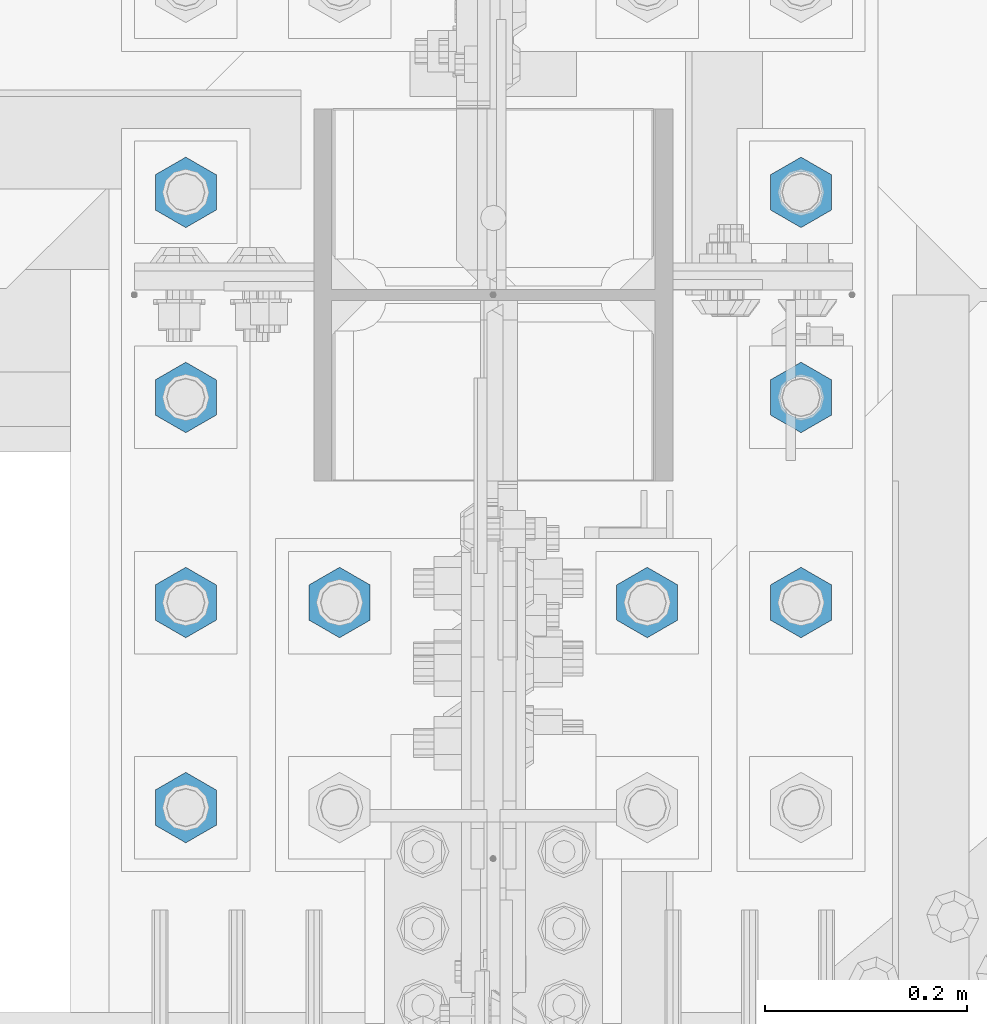
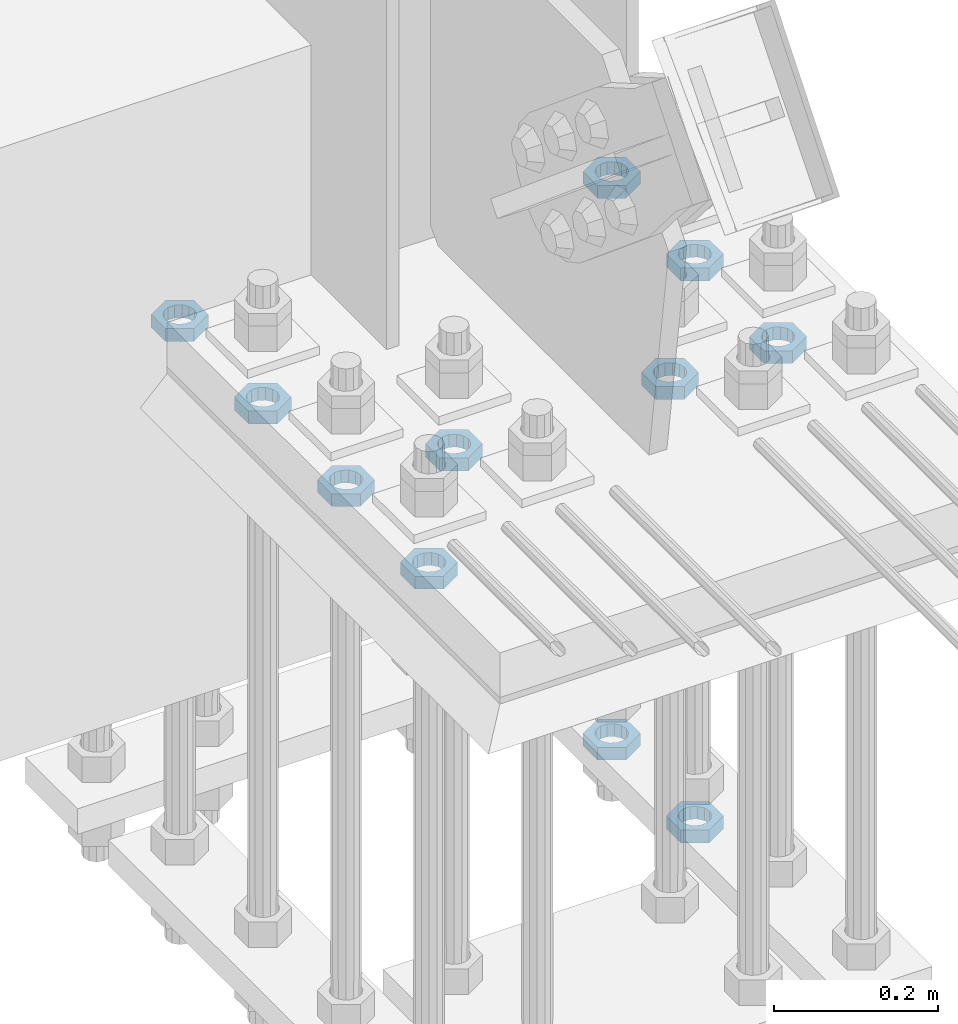
# One storey, part 2839 of 3843: 11 beams, 1 element without a shape of its own.
"""IFC2X3 building model written with IfcOpenShell, lengths in millimetres."""

from ifc_helpers import new_model, si_unit, frame, origin_with_axes, place, context, subcontext, project, spatial, faceted_brep, material, type_object, element, aggregate, save


model = new_model("IFC2X3")

# Units and contexts
model_context = context("Model", 3, precision=1e-05, world=origin_with_axes())
body_context = subcontext(model_context, "Body", "Model", "MODEL_VIEW")
ifc_project = project(units=[si_unit("LENGTHUNIT", "METRE", prefix="MILLI"), si_unit("AREAUNIT", "SQUARE_METRE"), si_unit("VOLUMEUNIT", "CUBIC_METRE"), si_unit("MASSUNIT", "GRAM", prefix="KILO"), si_unit("TIMEUNIT", "SECOND"), si_unit("PLANEANGLEUNIT", "RADIAN"), si_unit("SOLIDANGLEUNIT", "STERADIAN"), si_unit("THERMODYNAMICTEMPERATUREUNIT", "DEGREE_CELSIUS"), si_unit("LUMINOUSINTENSITYUNIT", "LUMEN")], contexts=[model_context])

# Site, building, storey
site_placement = place(None, origin_with_axes())
site = spatial("IfcSite", under=ifc_project, at=site_placement, CompositionType="ELEMENT")
building_placement = place(site_placement, origin_with_axes())
building = spatial("IfcBuilding", under=site, at=building_placement, Name="Undefined", CompositionType="ELEMENT")
storey_placement = place(building_placement, origin_with_axes())
storey = spatial("IfcBuildingStorey", under=building, at=storey_placement, Name="Undefined", CompositionType="ELEMENT", Elevation=0.0)

# Assembly, beams
assembly_placement = place(storey_placement, origin_with_axes())
assembly = element("IfcElementAssembly", 1, at=assembly_placement, inside=storey, Name="TEMPLATE", AssemblyPlace="NOTDEFINED", PredefinedType="RIGID_FRAME")
ifc_material = material(Name="STEEL/A572-50")
beam_type = type_object("IfcBeamType", Name="1-1/2_HALF_NUT", PredefinedType="NOTDEFINED")
beam_1_placement = place(assembly_placement, frame((76708.0, 25107.9, 30060.9), z_axis=(-1.0, 0.0, 0.0), x_axis=(0.0, 0.0, -1.0)))
beam_1 = element("IfcBeam", 2, at=beam_1_placement, type_object=beam_type, material=ifc_material, Name="NUT", ObjectType="1-1/2_HALF_NUT", context=body_context, shape_type="Brep", body=[
    faceted_brep([(0.0, -34.9199981689453, 0.0), (0.0, -17.4599990844727, -30.25), (19.0500000000029, -17.4599990844727, -30.25), (19.0500000000029, -34.9199981689453, 0.0), (0.0, 17.4599990844727, -30.25), (19.0500000000029, 17.4599990844727, -30.25), (0.0, 34.9199981689453, 0.0), (19.0500000000029, 34.9199981689453, 0.0), (0.0, 17.4599990844727, 30.25), (19.0500000000029, 17.4599990844727, 30.25), (0.0, -17.4599990844727, 30.25), (19.0500000000029, -17.4599990844727, 30.25), (0.0, 0.0, 20.6399993896484), (0.0, 8.9553601105581, 18.5959968835959), (19.0500000000029, 8.95536011056538, 18.5959968835959), (19.0500000000029, 0.0, 20.6399993896484), (0.0, 16.1370013209525, 12.8688291298167), (19.0500000000029, 16.1370013209489, 12.8688291298167), (0.0, 20.1225115123816, 4.59283194104501), (19.0500000000029, 20.1225115123852, 4.59283194104501), (0.0, 20.1225115123816, -4.59283194104501), (19.0500000000029, 20.1225115123852, -4.59283194104501), (0.0, 16.1370013209525, -12.8688291298167), (19.0500000000029, 16.1370013209489, -12.8688291298167), (0.0, 8.9553601105581, -18.5959968835959), (19.0500000000029, 8.95536011056538, -18.5959968835959), (0.0, 0.0, -20.6399993896484), (19.0500000000029, 0.0, -20.6399993896484), (0.0, -8.9553601105581, -18.5959968835959), (19.0500000000029, -8.95536011056538, -18.5959968835959), (0.0, -16.1370013209525, -12.8688291298167), (19.0500000000029, -16.1370013209489, -12.8688291298167), (0.0, -20.1225115123816, -4.59283194104501), (19.0500000000029, -20.1225115123852, -4.59283194104501), (0.0, -20.1225115123816, 4.59283194104501), (19.0500000000029, -20.1225115123852, 4.59283194104501), (0.0, -16.1370013209525, 12.8688291298167), (19.0500000000029, -16.1370013209489, 12.8688291298167), (0.0, -8.9553601105581, 18.5959968835959), (19.0500000000029, -8.95536011056538, 18.5959968835959)], [[[0, 1, 2, 3]], [[1, 4, 5, 2]], [[4, 6, 7, 5]], [[6, 8, 9, 7]], [[8, 10, 11, 9]], [[10, 0, 3, 11]], [[12, 13, 14, 15]], [[13, 16, 17, 14]], [[16, 18, 19, 17]], [[18, 20, 21, 19]], [[20, 22, 23, 21]], [[22, 24, 25, 23]], [[24, 26, 27, 25]], [[26, 28, 29, 27]], [[28, 30, 31, 29]], [[30, 32, 33, 31]], [[32, 34, 35, 33]], [[34, 36, 37, 35]], [[36, 38, 39, 37]], [[38, 12, 15, 39]], [[5, 7, 9, 11, 3, 2], [17, 19, 21, 23, 25, 27, 29, 31, 33, 35, 37, 39, 15, 14]], [[10, 8, 6, 4, 1, 0], [38, 36, 34, 32, 30, 28, 26, 24, 22, 20, 18, 16, 13, 12]]]),
])
beam_2_placement = place(assembly_placement, frame((77317.6, 25514.3, 30060.9), z_axis=(-1.0, 0.0, 0.0), x_axis=(0.0, 0.0, -1.0)))
beam_2 = element("IfcBeam", 3, at=beam_2_placement, type_object=beam_type, material=ifc_material, Name="NUT", ObjectType="1-1/2_HALF_NUT", context=body_context, shape_type="Brep", body=[
    faceted_brep([(0.0, -34.9199981689453, 0.0), (0.0, -17.4599990844727, -30.25), (19.0500000000029, -17.4599990844727, -30.25), (19.0500000000029, -34.9199981689453, 0.0), (0.0, 17.4599990844727, -30.25), (19.0500000000029, 17.4599990844727, -30.25), (0.0, 34.9199981689453, 0.0), (19.0500000000029, 34.9199981689453, 0.0), (0.0, 17.4599990844727, 30.25), (19.0500000000029, 17.4599990844727, 30.25), (0.0, -17.4599990844727, 30.25), (19.0500000000029, -17.4599990844727, 30.25), (0.0, 0.0, 20.6399993896484), (0.0, 8.9553601105581, 18.5959968835959), (19.0500000000029, 8.95536011056538, 18.5959968835959), (19.0500000000029, 0.0, 20.6399993896484), (0.0, 16.1370013209525, 12.8688291298167), (19.0500000000029, 16.1370013209489, 12.8688291298167), (0.0, 20.1225115123816, 4.59283194104501), (19.0500000000029, 20.1225115123852, 4.59283194104501), (0.0, 20.1225115123816, -4.59283194104501), (19.0500000000029, 20.1225115123852, -4.59283194104501), (0.0, 16.1370013209525, -12.8688291298167), (19.0500000000029, 16.1370013209489, -12.8688291298167), (0.0, 8.9553601105581, -18.5959968835959), (19.0500000000029, 8.95536011056538, -18.5959968835959), (0.0, 0.0, -20.6399993896484), (19.0500000000029, 0.0, -20.6399993896484), (0.0, -8.9553601105581, -18.5959968835959), (19.0500000000029, -8.95536011056538, -18.5959968835959), (0.0, -16.1370013209525, -12.8688291298167), (19.0500000000029, -16.1370013209489, -12.8688291298167), (0.0, -20.1225115123816, -4.59283194104501), (19.0500000000029, -20.1225115123852, -4.59283194104501), (0.0, -20.1225115123816, 4.59283194104501), (19.0500000000029, -20.1225115123852, 4.59283194104501), (0.0, -16.1370013209525, 12.8688291298167), (19.0500000000029, -16.1370013209489, 12.8688291298167), (0.0, -8.9553601105581, 18.5959968835959), (19.0500000000029, -8.95536011056538, 18.5959968835959)], [[[0, 1, 2, 3]], [[1, 4, 5, 2]], [[4, 6, 7, 5]], [[6, 8, 9, 7]], [[8, 10, 11, 9]], [[10, 0, 3, 11]], [[12, 13, 14, 15]], [[13, 16, 17, 14]], [[16, 18, 19, 17]], [[18, 20, 21, 19]], [[20, 22, 23, 21]], [[22, 24, 25, 23]], [[24, 26, 27, 25]], [[26, 28, 29, 27]], [[28, 30, 31, 29]], [[30, 32, 33, 31]], [[32, 34, 35, 33]], [[34, 36, 37, 35]], [[36, 38, 39, 37]], [[38, 12, 15, 39]], [[5, 7, 9, 11, 3, 2], [17, 19, 21, 23, 25, 27, 29, 31, 33, 35, 37, 39, 15, 14]], [[10, 8, 6, 4, 1, 0], [38, 36, 34, 32, 30, 28, 26, 24, 22, 20, 18, 16, 13, 12]]]),
])
beam_3_placement = place(assembly_placement, frame((77317.6, 25717.5, 30060.9), z_axis=(1.0, 0.0, 0.0), x_axis=(0.0, 0.0, -1.0)))
beam_3 = element("IfcBeam", 4, at=beam_3_placement, type_object=beam_type, material=ifc_material, Name="NUT", ObjectType="1-1/2_HALF_NUT", context=body_context, shape_type="Brep", body=[
    faceted_brep([(0.0, -34.9199981689453, 0.0), (0.0, -17.4599990844727, -30.25), (19.0500000000029, -17.4599990844727, -30.25), (19.0500000000029, -34.9199981689453, 0.0), (0.0, 17.4599990844727, -30.25), (19.0500000000029, 17.4599990844727, -30.25), (0.0, 34.9199981689453, 0.0), (19.0500000000029, 34.9199981689453, 0.0), (0.0, 17.4599990844727, 30.25), (19.0500000000029, 17.4599990844727, 30.25), (0.0, -17.4599990844727, 30.25), (19.0500000000029, -17.4599990844727, 30.25), (0.0, 0.0, 20.6399993896484), (0.0, 8.9553601105581, 18.5959968835959), (19.0500000000029, 8.95536011056538, 18.5959968835959), (19.0500000000029, 0.0, 20.6399993896484), (0.0, 16.1370013209525, 12.8688291298167), (19.0500000000029, 16.1370013209489, 12.8688291298167), (0.0, 20.1225115123816, 4.59283194104501), (19.0500000000029, 20.1225115123852, 4.59283194104501), (0.0, 20.1225115123816, -4.59283194104501), (19.0500000000029, 20.1225115123852, -4.59283194104501), (0.0, 16.1370013209525, -12.8688291298167), (19.0500000000029, 16.1370013209489, -12.8688291298167), (0.0, 8.9553601105581, -18.5959968835959), (19.0500000000029, 8.95536011056538, -18.5959968835959), (0.0, 0.0, -20.6399993896484), (19.0500000000029, 0.0, -20.6399993896484), (0.0, -8.9553601105581, -18.5959968835959), (19.0500000000029, -8.95536011056538, -18.5959968835959), (0.0, -16.1370013209525, -12.8688291298167), (19.0500000000029, -16.1370013209489, -12.8688291298167), (0.0, -20.1225115123816, -4.59283194104501), (19.0500000000029, -20.1225115123852, -4.59283194104501), (0.0, -20.1225115123816, 4.59283194104501), (19.0500000000029, -20.1225115123852, 4.59283194104501), (0.0, -16.1370013209525, 12.8688291298167), (19.0500000000029, -16.1370013209489, 12.8688291298167), (0.0, -8.9553601105581, 18.5959968835959), (19.0500000000029, -8.95536011056538, 18.5959968835959)], [[[0, 1, 2, 3]], [[1, 4, 5, 2]], [[4, 6, 7, 5]], [[6, 8, 9, 7]], [[8, 10, 11, 9]], [[10, 0, 3, 11]], [[12, 13, 14, 15]], [[13, 16, 17, 14]], [[16, 18, 19, 17]], [[18, 20, 21, 19]], [[20, 22, 23, 21]], [[22, 24, 25, 23]], [[24, 26, 27, 25]], [[26, 28, 29, 27]], [[28, 30, 31, 29]], [[30, 32, 33, 31]], [[32, 34, 35, 33]], [[34, 36, 37, 35]], [[36, 38, 39, 37]], [[38, 12, 15, 39]], [[5, 7, 9, 11, 3, 2], [17, 19, 21, 23, 25, 27, 29, 31, 33, 35, 37, 39, 15, 14]], [[10, 8, 6, 4, 1, 0], [38, 36, 34, 32, 30, 28, 26, 24, 22, 20, 18, 16, 13, 12]]]),
])
beam_4_placement = place(assembly_placement, frame((77317.6, 25311.1, 30060.9), z_axis=(-1.0, 0.0, 0.0), x_axis=(0.0, 0.0, -1.0)))
beam_4 = element("IfcBeam", 5, at=beam_4_placement, type_object=beam_type, material=ifc_material, Name="NUT", ObjectType="1-1/2_HALF_NUT", context=body_context, shape_type="Brep", body=[
    faceted_brep([(0.0, -34.9199981689453, 0.0), (0.0, -17.4599990844727, -30.25), (19.0500000000029, -17.4599990844727, -30.25), (19.0500000000029, -34.9199981689453, 0.0), (0.0, 17.4599990844727, -30.25), (19.0500000000029, 17.4599990844727, -30.25), (0.0, 34.9199981689453, 0.0), (19.0500000000029, 34.9199981689453, 0.0), (0.0, 17.4599990844727, 30.25), (19.0500000000029, 17.4599990844727, 30.25), (0.0, -17.4599990844727, 30.25), (19.0500000000029, -17.4599990844727, 30.25), (0.0, 0.0, 20.6399993896484), (0.0, 8.9553601105581, 18.5959968835959), (19.0500000000029, 8.95536011056538, 18.5959968835959), (19.0500000000029, 0.0, 20.6399993896484), (0.0, 16.1370013209525, 12.8688291298167), (19.0500000000029, 16.1370013209489, 12.8688291298167), (0.0, 20.1225115123816, 4.59283194104501), (19.0500000000029, 20.1225115123852, 4.59283194104501), (0.0, 20.1225115123816, -4.59283194104501), (19.0500000000029, 20.1225115123852, -4.59283194104501), (0.0, 16.1370013209525, -12.8688291298167), (19.0500000000029, 16.1370013209489, -12.8688291298167), (0.0, 8.9553601105581, -18.5959968835959), (19.0500000000029, 8.95536011056538, -18.5959968835959), (0.0, 0.0, -20.6399993896484), (19.0500000000029, 0.0, -20.6399993896484), (0.0, -8.9553601105581, -18.5959968835959), (19.0500000000029, -8.95536011056538, -18.5959968835959), (0.0, -16.1370013209525, -12.8688291298167), (19.0500000000029, -16.1370013209489, -12.8688291298167), (0.0, -20.1225115123816, -4.59283194104501), (19.0500000000029, -20.1225115123852, -4.59283194104501), (0.0, -20.1225115123816, 4.59283194104501), (19.0500000000029, -20.1225115123852, 4.59283194104501), (0.0, -16.1370013209525, 12.8688291298167), (19.0500000000029, -16.1370013209489, 12.8688291298167), (0.0, -8.9553601105581, 18.5959968835959), (19.0500000000029, -8.95536011056538, 18.5959968835959)], [[[0, 1, 2, 3]], [[1, 4, 5, 2]], [[4, 6, 7, 5]], [[6, 8, 9, 7]], [[8, 10, 11, 9]], [[10, 0, 3, 11]], [[12, 13, 14, 15]], [[13, 16, 17, 14]], [[16, 18, 19, 17]], [[18, 20, 21, 19]], [[20, 22, 23, 21]], [[22, 24, 25, 23]], [[24, 26, 27, 25]], [[26, 28, 29, 27]], [[28, 30, 31, 29]], [[30, 32, 33, 31]], [[32, 34, 35, 33]], [[34, 36, 37, 35]], [[36, 38, 39, 37]], [[38, 12, 15, 39]], [[5, 7, 9, 11, 3, 2], [17, 19, 21, 23, 25, 27, 29, 31, 33, 35, 37, 39, 15, 14]], [[10, 8, 6, 4, 1, 0], [38, 36, 34, 32, 30, 28, 26, 24, 22, 20, 18, 16, 13, 12]]]),
])
beam_5_placement = place(assembly_placement, frame((77165.2, 25311.1, 30060.9), z_axis=(-1.0, 0.0, 0.0), x_axis=(0.0, 0.0, -1.0)))
beam_5 = element("IfcBeam", 6, at=beam_5_placement, type_object=beam_type, material=ifc_material, Name="NUT", ObjectType="1-1/2_HALF_NUT", context=body_context, shape_type="Brep", body=[
    faceted_brep([(0.0, -34.9199981689453, 0.0), (0.0, -17.4599990844727, -30.25), (19.0500000000029, -17.4599990844727, -30.25), (19.0500000000029, -34.9199981689453, 0.0), (0.0, 17.4599990844727, -30.25), (19.0500000000029, 17.4599990844727, -30.25), (0.0, 34.9199981689453, 0.0), (19.0500000000029, 34.9199981689453, 0.0), (0.0, 17.4599990844727, 30.25), (19.0500000000029, 17.4599990844727, 30.25), (0.0, -17.4599990844727, 30.25), (19.0500000000029, -17.4599990844727, 30.25), (0.0, 0.0, 20.6399993896484), (0.0, 8.9553601105581, 18.5959968835959), (19.0500000000029, 8.95536011056538, 18.5959968835959), (19.0500000000029, 0.0, 20.6399993896484), (0.0, 16.1370013209525, 12.8688291298167), (19.0500000000029, 16.1370013209489, 12.8688291298167), (0.0, 20.1225115123816, 4.59283194104501), (19.0500000000029, 20.1225115123852, 4.59283194104501), (0.0, 20.1225115123816, -4.59283194104501), (19.0500000000029, 20.1225115123852, -4.59283194104501), (0.0, 16.1370013209525, -12.8688291298167), (19.0500000000029, 16.1370013209489, -12.8688291298167), (0.0, 8.9553601105581, -18.5959968835959), (19.0500000000029, 8.95536011056538, -18.5959968835959), (0.0, 0.0, -20.6399993896484), (19.0500000000029, 0.0, -20.6399993896484), (0.0, -8.9553601105581, -18.5959968835959), (19.0500000000029, -8.95536011056538, -18.5959968835959), (0.0, -16.1370013209525, -12.8688291298167), (19.0500000000029, -16.1370013209489, -12.8688291298167), (0.0, -20.1225115123816, -4.59283194104501), (19.0500000000029, -20.1225115123852, -4.59283194104501), (0.0, -20.1225115123816, 4.59283194104501), (19.0500000000029, -20.1225115123852, 4.59283194104501), (0.0, -16.1370013209525, 12.8688291298167), (19.0500000000029, -16.1370013209489, 12.8688291298167), (0.0, -8.9553601105581, 18.5959968835959), (19.0500000000029, -8.95536011056538, 18.5959968835959)], [[[0, 1, 2, 3]], [[1, 4, 5, 2]], [[4, 6, 7, 5]], [[6, 8, 9, 7]], [[8, 10, 11, 9]], [[10, 0, 3, 11]], [[12, 13, 14, 15]], [[13, 16, 17, 14]], [[16, 18, 19, 17]], [[18, 20, 21, 19]], [[20, 22, 23, 21]], [[22, 24, 25, 23]], [[24, 26, 27, 25]], [[26, 28, 29, 27]], [[28, 30, 31, 29]], [[30, 32, 33, 31]], [[32, 34, 35, 33]], [[34, 36, 37, 35]], [[36, 38, 39, 37]], [[38, 12, 15, 39]], [[5, 7, 9, 11, 3, 2], [17, 19, 21, 23, 25, 27, 29, 31, 33, 35, 37, 39, 15, 14]], [[10, 8, 6, 4, 1, 0], [38, 36, 34, 32, 30, 28, 26, 24, 22, 20, 18, 16, 13, 12]]]),
])
beam_6_placement = place(assembly_placement, frame((76860.4, 25311.1, 30060.9), z_axis=(-1.0, 0.0, 0.0), x_axis=(0.0, 0.0, -1.0)))
beam_6 = element("IfcBeam", 7, at=beam_6_placement, type_object=beam_type, material=ifc_material, Name="NUT", ObjectType="1-1/2_HALF_NUT", context=body_context, shape_type="Brep", body=[
    faceted_brep([(0.0, -34.9199981689453, 0.0), (0.0, -17.4599990844727, -30.25), (19.0500000000029, -17.4599990844727, -30.25), (19.0500000000029, -34.9199981689453, 0.0), (0.0, 17.4599990844727, -30.25), (19.0500000000029, 17.4599990844727, -30.25), (0.0, 34.9199981689453, 0.0), (19.0500000000029, 34.9199981689453, 0.0), (0.0, 17.4599990844727, 30.25), (19.0500000000029, 17.4599990844727, 30.25), (0.0, -17.4599990844727, 30.25), (19.0500000000029, -17.4599990844727, 30.25), (0.0, 0.0, 20.6399993896484), (0.0, 8.9553601105581, 18.5959968835959), (19.0500000000029, 8.95536011056538, 18.5959968835959), (19.0500000000029, 0.0, 20.6399993896484), (0.0, 16.1370013209525, 12.8688291298167), (19.0500000000029, 16.1370013209489, 12.8688291298167), (0.0, 20.1225115123816, 4.59283194104501), (19.0500000000029, 20.1225115123852, 4.59283194104501), (0.0, 20.1225115123816, -4.59283194104501), (19.0500000000029, 20.1225115123852, -4.59283194104501), (0.0, 16.1370013209525, -12.8688291298167), (19.0500000000029, 16.1370013209489, -12.8688291298167), (0.0, 8.9553601105581, -18.5959968835959), (19.0500000000029, 8.95536011056538, -18.5959968835959), (0.0, 0.0, -20.6399993896484), (19.0500000000029, 0.0, -20.6399993896484), (0.0, -8.9553601105581, -18.5959968835959), (19.0500000000029, -8.95536011056538, -18.5959968835959), (0.0, -16.1370013209525, -12.8688291298167), (19.0500000000029, -16.1370013209489, -12.8688291298167), (0.0, -20.1225115123816, -4.59283194104501), (19.0500000000029, -20.1225115123852, -4.59283194104501), (0.0, -20.1225115123816, 4.59283194104501), (19.0500000000029, -20.1225115123852, 4.59283194104501), (0.0, -16.1370013209525, 12.8688291298167), (19.0500000000029, -16.1370013209489, 12.8688291298167), (0.0, -8.9553601105581, 18.5959968835959), (19.0500000000029, -8.95536011056538, 18.5959968835959)], [[[0, 1, 2, 3]], [[1, 4, 5, 2]], [[4, 6, 7, 5]], [[6, 8, 9, 7]], [[8, 10, 11, 9]], [[10, 0, 3, 11]], [[12, 13, 14, 15]], [[13, 16, 17, 14]], [[16, 18, 19, 17]], [[18, 20, 21, 19]], [[20, 22, 23, 21]], [[22, 24, 25, 23]], [[24, 26, 27, 25]], [[26, 28, 29, 27]], [[28, 30, 31, 29]], [[30, 32, 33, 31]], [[32, 34, 35, 33]], [[34, 36, 37, 35]], [[36, 38, 39, 37]], [[38, 12, 15, 39]], [[5, 7, 9, 11, 3, 2], [17, 19, 21, 23, 25, 27, 29, 31, 33, 35, 37, 39, 15, 14]], [[10, 8, 6, 4, 1, 0], [38, 36, 34, 32, 30, 28, 26, 24, 22, 20, 18, 16, 13, 12]]]),
])
beam_7_placement = place(assembly_placement, frame((76708.0, 25717.5, 30060.9), z_axis=(1.0, 0.0, 0.0), x_axis=(0.0, 0.0, -1.0)))
beam_7 = element("IfcBeam", 8, at=beam_7_placement, type_object=beam_type, material=ifc_material, Name="NUT", ObjectType="1-1/2_HALF_NUT", context=body_context, shape_type="Brep", body=[
    faceted_brep([(0.0, -34.9199981689453, 0.0), (0.0, -17.4599990844727, -30.25), (19.0500000000029, -17.4599990844727, -30.25), (19.0500000000029, -34.9199981689453, 0.0), (0.0, 17.4599990844727, -30.25), (19.0500000000029, 17.4599990844727, -30.25), (0.0, 34.9199981689453, 0.0), (19.0500000000029, 34.9199981689453, 0.0), (0.0, 17.4599990844727, 30.25), (19.0500000000029, 17.4599990844727, 30.25), (0.0, -17.4599990844727, 30.25), (19.0500000000029, -17.4599990844727, 30.25), (0.0, 0.0, 20.6399993896484), (0.0, 8.9553601105581, 18.5959968835959), (19.0500000000029, 8.95536011056538, 18.5959968835959), (19.0500000000029, 0.0, 20.6399993896484), (0.0, 16.1370013209525, 12.8688291298167), (19.0500000000029, 16.1370013209489, 12.8688291298167), (0.0, 20.1225115123816, 4.59283194104501), (19.0500000000029, 20.1225115123852, 4.59283194104501), (0.0, 20.1225115123816, -4.59283194104501), (19.0500000000029, 20.1225115123852, -4.59283194104501), (0.0, 16.1370013209525, -12.8688291298167), (19.0500000000029, 16.1370013209489, -12.8688291298167), (0.0, 8.9553601105581, -18.5959968835959), (19.0500000000029, 8.95536011056538, -18.5959968835959), (0.0, 0.0, -20.6399993896484), (19.0500000000029, 0.0, -20.6399993896484), (0.0, -8.9553601105581, -18.5959968835959), (19.0500000000029, -8.95536011056538, -18.5959968835959), (0.0, -16.1370013209525, -12.8688291298167), (19.0500000000029, -16.1370013209489, -12.8688291298167), (0.0, -20.1225115123816, -4.59283194104501), (19.0500000000029, -20.1225115123852, -4.59283194104501), (0.0, -20.1225115123816, 4.59283194104501), (19.0500000000029, -20.1225115123852, 4.59283194104501), (0.0, -16.1370013209525, 12.8688291298167), (19.0500000000029, -16.1370013209489, 12.8688291298167), (0.0, -8.9553601105581, 18.5959968835959), (19.0500000000029, -8.95536011056538, 18.5959968835959)], [[[0, 1, 2, 3]], [[1, 4, 5, 2]], [[4, 6, 7, 5]], [[6, 8, 9, 7]], [[8, 10, 11, 9]], [[10, 0, 3, 11]], [[12, 13, 14, 15]], [[13, 16, 17, 14]], [[16, 18, 19, 17]], [[18, 20, 21, 19]], [[20, 22, 23, 21]], [[22, 24, 25, 23]], [[24, 26, 27, 25]], [[26, 28, 29, 27]], [[28, 30, 31, 29]], [[30, 32, 33, 31]], [[32, 34, 35, 33]], [[34, 36, 37, 35]], [[36, 38, 39, 37]], [[38, 12, 15, 39]], [[5, 7, 9, 11, 3, 2], [17, 19, 21, 23, 25, 27, 29, 31, 33, 35, 37, 39, 15, 14]], [[10, 8, 6, 4, 1, 0], [38, 36, 34, 32, 30, 28, 26, 24, 22, 20, 18, 16, 13, 12]]]),
])
beam_8_placement = place(assembly_placement, frame((76708.0, 25514.3, 30060.9), z_axis=(-1.0, 0.0, 0.0), x_axis=(0.0, 0.0, -1.0)))
beam_8 = element("IfcBeam", 9, at=beam_8_placement, type_object=beam_type, material=ifc_material, Name="NUT", ObjectType="1-1/2_HALF_NUT", context=body_context, shape_type="Brep", body=[
    faceted_brep([(0.0, -34.9199981689453, 0.0), (0.0, -17.4599990844727, -30.25), (19.0500000000029, -17.4599990844727, -30.25), (19.0500000000029, -34.9199981689453, 0.0), (0.0, 17.4599990844727, -30.25), (19.0500000000029, 17.4599990844727, -30.25), (0.0, 34.9199981689453, 0.0), (19.0500000000029, 34.9199981689453, 0.0), (0.0, 17.4599990844727, 30.25), (19.0500000000029, 17.4599990844727, 30.25), (0.0, -17.4599990844727, 30.25), (19.0500000000029, -17.4599990844727, 30.25), (0.0, 0.0, 20.6399993896484), (0.0, 8.9553601105581, 18.5959968835959), (19.0500000000029, 8.95536011056538, 18.5959968835959), (19.0500000000029, 0.0, 20.6399993896484), (0.0, 16.1370013209525, 12.8688291298167), (19.0500000000029, 16.1370013209489, 12.8688291298167), (0.0, 20.1225115123816, 4.59283194104501), (19.0500000000029, 20.1225115123852, 4.59283194104501), (0.0, 20.1225115123816, -4.59283194104501), (19.0500000000029, 20.1225115123852, -4.59283194104501), (0.0, 16.1370013209525, -12.8688291298167), (19.0500000000029, 16.1370013209489, -12.8688291298167), (0.0, 8.9553601105581, -18.5959968835959), (19.0500000000029, 8.95536011056538, -18.5959968835959), (0.0, 0.0, -20.6399993896484), (19.0500000000029, 0.0, -20.6399993896484), (0.0, -8.9553601105581, -18.5959968835959), (19.0500000000029, -8.95536011056538, -18.5959968835959), (0.0, -16.1370013209525, -12.8688291298167), (19.0500000000029, -16.1370013209489, -12.8688291298167), (0.0, -20.1225115123816, -4.59283194104501), (19.0500000000029, -20.1225115123852, -4.59283194104501), (0.0, -20.1225115123816, 4.59283194104501), (19.0500000000029, -20.1225115123852, 4.59283194104501), (0.0, -16.1370013209525, 12.8688291298167), (19.0500000000029, -16.1370013209489, 12.8688291298167), (0.0, -8.9553601105581, 18.5959968835959), (19.0500000000029, -8.95536011056538, 18.5959968835959)], [[[0, 1, 2, 3]], [[1, 4, 5, 2]], [[4, 6, 7, 5]], [[6, 8, 9, 7]], [[8, 10, 11, 9]], [[10, 0, 3, 11]], [[12, 13, 14, 15]], [[13, 16, 17, 14]], [[16, 18, 19, 17]], [[18, 20, 21, 19]], [[20, 22, 23, 21]], [[22, 24, 25, 23]], [[24, 26, 27, 25]], [[26, 28, 29, 27]], [[28, 30, 31, 29]], [[30, 32, 33, 31]], [[32, 34, 35, 33]], [[34, 36, 37, 35]], [[36, 38, 39, 37]], [[38, 12, 15, 39]], [[5, 7, 9, 11, 3, 2], [17, 19, 21, 23, 25, 27, 29, 31, 33, 35, 37, 39, 15, 14]], [[10, 8, 6, 4, 1, 0], [38, 36, 34, 32, 30, 28, 26, 24, 22, 20, 18, 16, 13, 12]]]),
])
beam_9_placement = place(assembly_placement, frame((76708.0, 25311.1, 30060.9), z_axis=(-1.0, 0.0, 0.0), x_axis=(0.0, 0.0, -1.0)))
beam_9 = element("IfcBeam", 10, at=beam_9_placement, type_object=beam_type, material=ifc_material, Name="NUT", ObjectType="1-1/2_HALF_NUT", context=body_context, shape_type="Brep", body=[
    faceted_brep([(0.0, -34.9199981689453, 0.0), (0.0, -17.4599990844727, -30.25), (19.0500000000029, -17.4599990844727, -30.25), (19.0500000000029, -34.9199981689453, 0.0), (0.0, 17.4599990844727, -30.25), (19.0500000000029, 17.4599990844727, -30.25), (0.0, 34.9199981689453, 0.0), (19.0500000000029, 34.9199981689453, 0.0), (0.0, 17.4599990844727, 30.25), (19.0500000000029, 17.4599990844727, 30.25), (0.0, -17.4599990844727, 30.25), (19.0500000000029, -17.4599990844727, 30.25), (0.0, 0.0, 20.6399993896484), (0.0, 8.9553601105581, 18.5959968835959), (19.0500000000029, 8.95536011056538, 18.5959968835959), (19.0500000000029, 0.0, 20.6399993896484), (0.0, 16.1370013209525, 12.8688291298167), (19.0500000000029, 16.1370013209489, 12.8688291298167), (0.0, 20.1225115123816, 4.59283194104501), (19.0500000000029, 20.1225115123852, 4.59283194104501), (0.0, 20.1225115123816, -4.59283194104501), (19.0500000000029, 20.1225115123852, -4.59283194104501), (0.0, 16.1370013209525, -12.8688291298167), (19.0500000000029, 16.1370013209489, -12.8688291298167), (0.0, 8.9553601105581, -18.5959968835959), (19.0500000000029, 8.95536011056538, -18.5959968835959), (0.0, 0.0, -20.6399993896484), (19.0500000000029, 0.0, -20.6399993896484), (0.0, -8.9553601105581, -18.5959968835959), (19.0500000000029, -8.95536011056538, -18.5959968835959), (0.0, -16.1370013209525, -12.8688291298167), (19.0500000000029, -16.1370013209489, -12.8688291298167), (0.0, -20.1225115123816, -4.59283194104501), (19.0500000000029, -20.1225115123852, -4.59283194104501), (0.0, -20.1225115123816, 4.59283194104501), (19.0500000000029, -20.1225115123852, 4.59283194104501), (0.0, -16.1370013209525, 12.8688291298167), (19.0500000000029, -16.1370013209489, 12.8688291298167), (0.0, -8.9553601105581, 18.5959968835959), (19.0500000000029, -8.95536011056538, 18.5959968835959)], [[[0, 1, 2, 3]], [[1, 4, 5, 2]], [[4, 6, 7, 5]], [[6, 8, 9, 7]], [[8, 10, 11, 9]], [[10, 0, 3, 11]], [[12, 13, 14, 15]], [[13, 16, 17, 14]], [[16, 18, 19, 17]], [[18, 20, 21, 19]], [[20, 22, 23, 21]], [[22, 24, 25, 23]], [[24, 26, 27, 25]], [[26, 28, 29, 27]], [[28, 30, 31, 29]], [[30, 32, 33, 31]], [[32, 34, 35, 33]], [[34, 36, 37, 35]], [[36, 38, 39, 37]], [[38, 12, 15, 39]], [[5, 7, 9, 11, 3, 2], [17, 19, 21, 23, 25, 27, 29, 31, 33, 35, 37, 39, 15, 14]], [[10, 8, 6, 4, 1, 0], [38, 36, 34, 32, 30, 28, 26, 24, 22, 20, 18, 16, 13, 12]]]),
])
beam_10_placement = place(assembly_placement, frame((77317.6, 25717.5, 29222.7000015259), z_axis=(1.0, 0.0, 0.0), x_axis=(0.0, 0.0, -1.0)))
beam_10 = element("IfcBeam", 11, at=beam_10_placement, type_object=beam_type, material=ifc_material, Name="NUT", ObjectType="1-1/2_HALF_NUT", context=body_context, shape_type="Brep", body=[
    faceted_brep([(0.0, -34.9199981689453, 0.0), (0.0, -17.4599990844727, -30.25), (19.0500000000029, -17.4599990844727, -30.25), (19.0500000000029, -34.9199981689453, 0.0), (0.0, 17.4599990844727, -30.25), (19.0500000000029, 17.4599990844727, -30.25), (0.0, 34.9199981689453, 0.0), (19.0500000000029, 34.9199981689453, 0.0), (0.0, 17.4599990844727, 30.25), (19.0500000000029, 17.4599990844727, 30.25), (0.0, -17.4599990844727, 30.25), (19.0500000000029, -17.4599990844727, 30.25), (0.0, 0.0, 20.6399993896484), (0.0, 8.9553601105581, 18.5959968835959), (19.0500000000029, 8.95536011056538, 18.5959968835959), (19.0500000000029, 0.0, 20.6399993896484), (0.0, 16.1370013209525, 12.8688291298167), (19.0500000000029, 16.1370013209489, 12.8688291298167), (0.0, 20.1225115123816, 4.59283194104501), (19.0500000000029, 20.1225115123852, 4.59283194104501), (0.0, 20.1225115123816, -4.59283194104501), (19.0500000000029, 20.1225115123852, -4.59283194104501), (0.0, 16.1370013209525, -12.8688291298167), (19.0500000000029, 16.1370013209489, -12.8688291298167), (0.0, 8.9553601105581, -18.5959968835959), (19.0500000000029, 8.95536011056538, -18.5959968835959), (0.0, 0.0, -20.6399993896484), (19.0500000000029, 0.0, -20.6399993896484), (0.0, -8.9553601105581, -18.5959968835959), (19.0500000000029, -8.95536011056538, -18.5959968835959), (0.0, -16.1370013209525, -12.8688291298167), (19.0500000000029, -16.1370013209489, -12.8688291298167), (0.0, -20.1225115123816, -4.59283194104501), (19.0500000000029, -20.1225115123852, -4.59283194104501), (0.0, -20.1225115123816, 4.59283194104501), (19.0500000000029, -20.1225115123852, 4.59283194104501), (0.0, -16.1370013209525, 12.8688291298167), (19.0500000000029, -16.1370013209489, 12.8688291298167), (0.0, -8.9553601105581, 18.5959968835959), (19.0500000000029, -8.95536011056538, 18.5959968835959)], [[[0, 1, 2, 3]], [[1, 4, 5, 2]], [[4, 6, 7, 5]], [[6, 8, 9, 7]], [[8, 10, 11, 9]], [[10, 0, 3, 11]], [[12, 13, 14, 15]], [[13, 16, 17, 14]], [[16, 18, 19, 17]], [[18, 20, 21, 19]], [[20, 22, 23, 21]], [[22, 24, 25, 23]], [[24, 26, 27, 25]], [[26, 28, 29, 27]], [[28, 30, 31, 29]], [[30, 32, 33, 31]], [[32, 34, 35, 33]], [[34, 36, 37, 35]], [[36, 38, 39, 37]], [[38, 12, 15, 39]], [[5, 7, 9, 11, 3, 2], [17, 19, 21, 23, 25, 27, 29, 31, 33, 35, 37, 39, 15, 14]], [[10, 8, 6, 4, 1, 0], [38, 36, 34, 32, 30, 28, 26, 24, 22, 20, 18, 16, 13, 12]]]),
])
beam_11_placement = place(assembly_placement, frame((77317.6, 25514.3, 29222.7000015259), z_axis=(1.0, 0.0, 0.0), x_axis=(0.0, 0.0, -1.0)))
beam_11 = element("IfcBeam", 12, at=beam_11_placement, type_object=beam_type, material=ifc_material, Name="NUT", ObjectType="1-1/2_HALF_NUT", context=body_context, shape_type="Brep", body=[
    faceted_brep([(0.0, -34.9199981689453, 0.0), (0.0, -17.4599990844727, -30.25), (19.0500000000029, -17.4599990844727, -30.25), (19.0500000000029, -34.9199981689453, 0.0), (0.0, 17.4599990844727, -30.25), (19.0500000000029, 17.4599990844727, -30.25), (0.0, 34.9199981689453, 0.0), (19.0500000000029, 34.9199981689453, 0.0), (0.0, 17.4599990844727, 30.25), (19.0500000000029, 17.4599990844727, 30.25), (0.0, -17.4599990844727, 30.25), (19.0500000000029, -17.4599990844727, 30.25), (0.0, 0.0, 20.6399993896484), (0.0, 8.9553601105581, 18.5959968835959), (19.0500000000029, 8.95536011056538, 18.5959968835959), (19.0500000000029, 0.0, 20.6399993896484), (0.0, 16.1370013209525, 12.8688291298167), (19.0500000000029, 16.1370013209489, 12.8688291298167), (0.0, 20.1225115123816, 4.59283194104501), (19.0500000000029, 20.1225115123852, 4.59283194104501), (0.0, 20.1225115123816, -4.59283194104501), (19.0500000000029, 20.1225115123852, -4.59283194104501), (0.0, 16.1370013209525, -12.8688291298167), (19.0500000000029, 16.1370013209489, -12.8688291298167), (0.0, 8.9553601105581, -18.5959968835959), (19.0500000000029, 8.95536011056538, -18.5959968835959), (0.0, 0.0, -20.6399993896484), (19.0500000000029, 0.0, -20.6399993896484), (0.0, -8.9553601105581, -18.5959968835959), (19.0500000000029, -8.95536011056538, -18.5959968835959), (0.0, -16.1370013209525, -12.8688291298167), (19.0500000000029, -16.1370013209489, -12.8688291298167), (0.0, -20.1225115123816, -4.59283194104501), (19.0500000000029, -20.1225115123852, -4.59283194104501), (0.0, -20.1225115123816, 4.59283194104501), (19.0500000000029, -20.1225115123852, 4.59283194104501), (0.0, -16.1370013209525, 12.8688291298167), (19.0500000000029, -16.1370013209489, 12.8688291298167), (0.0, -8.9553601105581, 18.5959968835959), (19.0500000000029, -8.95536011056538, 18.5959968835959)], [[[0, 1, 2, 3]], [[1, 4, 5, 2]], [[4, 6, 7, 5]], [[6, 8, 9, 7]], [[8, 10, 11, 9]], [[10, 0, 3, 11]], [[12, 13, 14, 15]], [[13, 16, 17, 14]], [[16, 18, 19, 17]], [[18, 20, 21, 19]], [[20, 22, 23, 21]], [[22, 24, 25, 23]], [[24, 26, 27, 25]], [[26, 28, 29, 27]], [[28, 30, 31, 29]], [[30, 32, 33, 31]], [[32, 34, 35, 33]], [[34, 36, 37, 35]], [[36, 38, 39, 37]], [[38, 12, 15, 39]], [[5, 7, 9, 11, 3, 2], [17, 19, 21, 23, 25, 27, 29, 31, 33, 35, 37, 39, 15, 14]], [[10, 8, 6, 4, 1, 0], [38, 36, 34, 32, 30, 28, 26, 24, 22, 20, 18, 16, 13, 12]]]),
])
aggregate(assembly, [beam_1, beam_2, beam_3, beam_4, beam_5, beam_6, beam_7, beam_8, beam_9, beam_10, beam_11])

save(model, "model.ifc")
